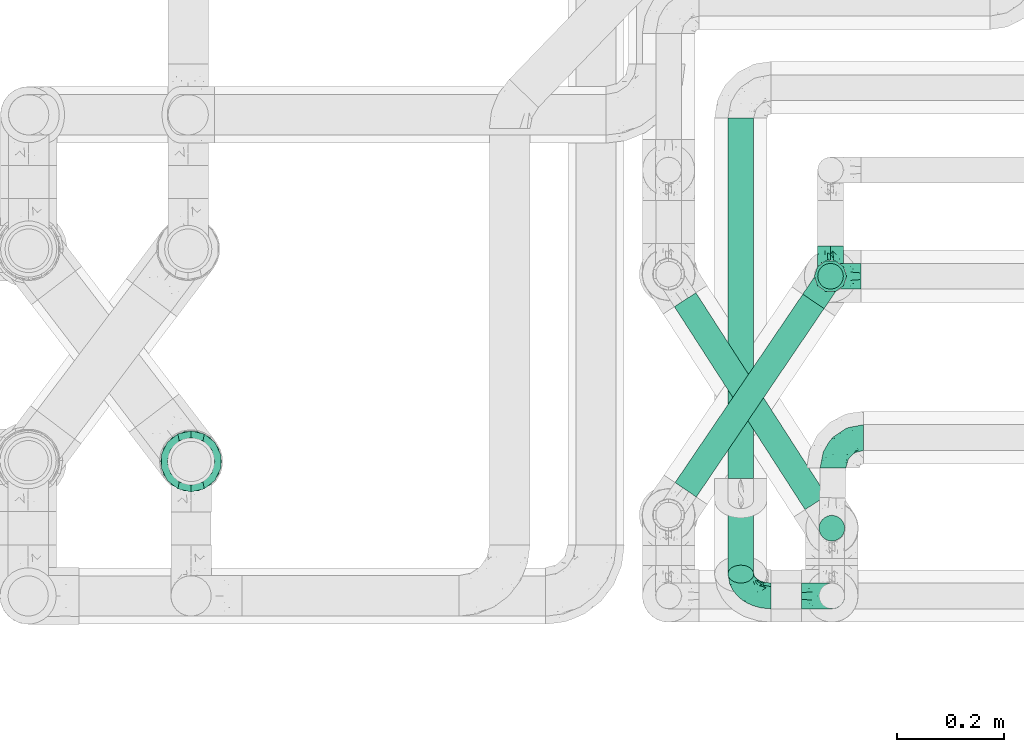
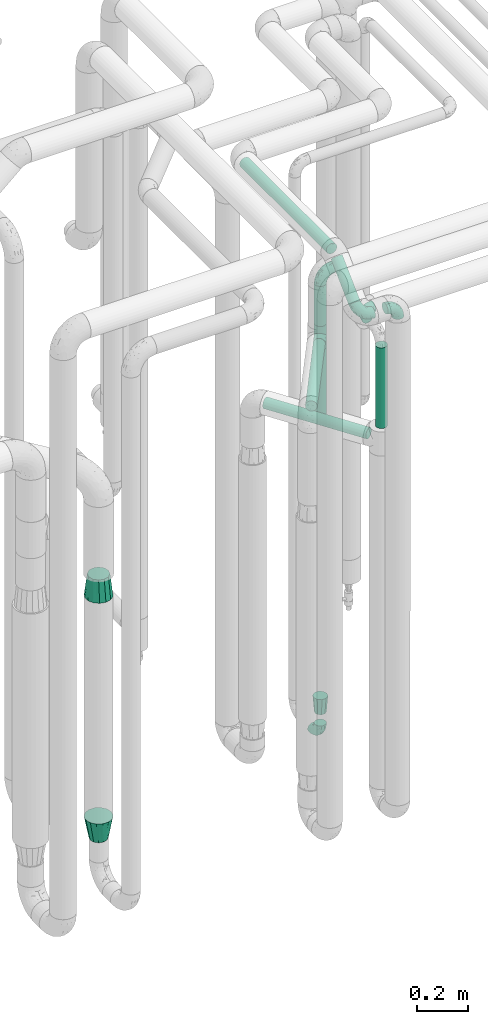
# One storey, part 662 of 827: 9 flow fittings, 7 flow segments.
"""IFC2X3 building model written with IfcOpenShell, lengths in millimetres."""

import ifcopenshell
import ifcopenshell.guid

model = None  # the IFC model being written
_history = None  # IfcOwnerHistory: only IFC2X3 demands one
_inside = {}  # id of a spatial element -> (the spatial element, [elements in it])
_under = {}  # id of a project, library or spatial element -> (it, [spatial elements below it])
_declared = {}  # id of a project -> (the project, [libraries it declares])
_typed = {}  # id of a type object -> (the type object, [elements of that type])
_made_of = {}  # id of a material, layer set ... -> (it, [elements and type objects made of it])


def new_model(schema):
    """Start an empty IFC model of exactly this schema.

    Asked for "IFC4X3", IfcOpenShell would pick the latest addendum, in which some entities
    have other attributes; the version numbers below select the first issue.
    IFC2X3 requires an IfcOwnerHistory on every rooted entity: one is made here for all.
    """
    global model, _history
    if schema == "IFC4X3":
        model = ifcopenshell.file(schema_version=(4, 3, 0, 0))
    else:
        model = ifcopenshell.file(schema=schema)
    _inside.clear()
    _under.clear()
    _declared.clear()
    _typed.clear()
    _made_of.clear()
    _history = None
    if model.schema == "IFC2X3":
        org = make("IfcOrganization", Name="unknown")
        user = make(
            "IfcPersonAndOrganization",
            ThePerson=make("IfcPerson", FamilyName="unknown"),
            TheOrganization=org,
        )
        app = make(
            "IfcApplication",
            ApplicationDeveloper=org,
            Version="unknown",
            ApplicationFullName="unknown",
            ApplicationIdentifier="unknown",
        )
        _history = make(
            "IfcOwnerHistory",
            OwningUser=user,
            OwningApplication=app,
            ChangeAction="ADDED",
            CreationDate=0,
        )
    return model


def make(cls, **values):
    """One entity of the class cls with the attributes given. An attribute that is None is left unset."""
    return model.create_entity(
        cls, **{name: value for name, value in values.items() if value is not None}
    )


def entity(cls, *values):
    """Any entity or typed value of the class cls, its attributes in the order of the schema. None: left unset."""
    e = model.create_entity(cls)
    for i, value in enumerate(values):
        if value is not None:
            e[i] = value
    return e


def rooted(cls, **values):
    """An entity with a GlobalId (a new one), such as an element, a storey or a relation."""
    return make(cls, GlobalId=ifcopenshell.guid.new(), OwnerHistory=_history, **values)


def si_unit(unit_type, name, prefix=None):
    """IfcSIUnit, for example si_unit("LENGTHUNIT", "METRE", prefix="MILLI")."""
    return make("IfcSIUnit", UnitType=unit_type, Prefix=prefix, Name=name)


def converted_unit(unit_type, name, factor, base, dimensions=None, offset=None):
    """IfcConversionBasedUnit, such as the inch: factor (a typed value) times the base unit."""
    return make(
        "IfcConversionBasedUnit"
        if offset is None
        else "IfcConversionBasedUnitWithOffset",
        ConversionOffset=offset,
        Dimensions=None
        if dimensions is None
        else entity("IfcDimensionalExponents", *dimensions),
        UnitType=unit_type,
        Name=name,
        ConversionFactor=make(
            "IfcMeasureWithUnit", ValueComponent=factor, UnitComponent=base
        ),
    )


def derived_unit(unit_type, elements):
    """IfcDerivedUnit: a product of units, each with its exponent."""
    return make(
        "IfcDerivedUnit",
        Elements=[
            make("IfcDerivedUnitElement", Unit=unit, Exponent=power)
            for unit, power in elements
        ],
        UnitType=unit_type,
    )


def assignment(units):
    """IfcUnitAssignment: the units of a project."""
    return None if units is None else make("IfcUnitAssignment", Units=units)


def point(xyz):
    """IfcCartesianPoint."""
    return None if xyz is None else make("IfcCartesianPoint", Coordinates=xyz)


def direction(xyz):
    """IfcDirection."""
    return None if xyz is None else make("IfcDirection", DirectionRatios=xyz)


def frame(location, z_axis=None, x_axis=None):
    """IfcAxis2Placement3D, a coordinate frame: its origin and axes. An axis left out is left unset."""
    return make(
        "IfcAxis2Placement3D",
        Location=point(location),
        Axis=direction(z_axis),
        RefDirection=direction(x_axis),
    )


def frame_2d(location, x_axis=None):
    """IfcAxis2Placement2D, a coordinate frame in the plane: its origin and x axis."""
    return make(
        "IfcAxis2Placement2D", Location=point(location), RefDirection=direction(x_axis)
    )


def origin():
    """The frame at (0, 0, 0) with its axes left unset."""
    return frame((0.0, 0.0, 0.0))


def origin_2d_with_axis():
    """The frame at (0, 0) in the plane with the x axis (1, 0) written out."""
    return frame_2d((0.0, 0.0), x_axis=(1.0, 0.0))


def place(relative_to, where):
    """IfcLocalPlacement: puts the frame where relative to a parent placement (None: the world)."""
    return make(
        "IfcLocalPlacement", PlacementRelTo=relative_to, RelativePlacement=where
    )


def context(
    kind, dimensions, precision=None, world=None, true_north=None, identifier=None
):
    """IfcGeometricRepresentationContext, for example the 3D "Model" context."""
    return make(
        "IfcGeometricRepresentationContext",
        ContextIdentifier=identifier,
        ContextType=kind,
        CoordinateSpaceDimension=dimensions,
        Precision=precision,
        WorldCoordinateSystem=world,
        TrueNorth=true_north,
    )


def subcontext(parent, identifier, kind, view, scale=None):
    """IfcGeometricRepresentationSubContext, for example "Body" below "Model"."""
    return make(
        "IfcGeometricRepresentationSubContext",
        ContextIdentifier=identifier,
        ContextType=kind,
        ParentContext=parent,
        TargetScale=scale,
        TargetView=view,
    )


def project(units=None, contexts=None):
    """IfcProject with its units and contexts."""
    return rooted(
        "IfcProject",
        Name="project",
        RepresentationContexts=contexts,
        UnitsInContext=assignment(units),
    )


def spatial(cls, under=None, at=None, **own):
    """A site, building, storey or space (cls), placed at a placement, below another one or the project."""
    s = rooted(cls, ObjectPlacement=at, **own)
    if under is not None:
        _under.setdefault(under.id(), (under, []))[1].append(s)
    return s


def profile(cls, at=None, kind="AREA", **sizes):
    """A parametric profile (cls). Its sizes go by their IFC names, for example OverallWidth=200.0."""
    return make(cls, ProfileType=kind, Position=at, **sizes)


def circle(**sizes):
    """IfcCircleProfileDef."""
    return profile("IfcCircleProfileDef", **sizes)


def extrude(swept, where, along, depth):
    """IfcExtrudedAreaSolid: the profile swept, set in the frame where, extruded along a direction by depth."""
    return make(
        "IfcExtrudedAreaSolid",
        SweptArea=swept,
        Position=where,
        ExtrudedDirection=direction(along),
        Depth=depth,
    )


def faces_of(points, faces, orient=None, outer=None):
    """IfcFace entities. A face is a list of loops; a loop is a list of indices into points, from 0.

    orient and outer hold one flag for each loop. By default every Orientation is true, the
    first loop of a face is its IfcFaceOuterBound and the others are IfcFaceBound.
    """
    made = []
    for i, loops in enumerate(faces):
        bounds = []
        for j, loop in enumerate(loops):
            is_outer = j == 0 if outer is None else outer[i][j]
            bounds.append(
                make(
                    "IfcFaceOuterBound" if is_outer else "IfcFaceBound",
                    Bound=make("IfcPolyLoop", Polygon=[points[k] for k in loop]),
                    Orientation=True if orient is None else orient[i][j],
                )
            )
        made.append(make("IfcFace", Bounds=bounds))
    return made


def faceted_brep(points, faces, orient=None, outer=None, voids=None):
    """IfcFacetedBrep: a solid bounded by flat faces; with voids (closed shells), ...WithVoids."""
    shared = [point(p) for p in points]
    hull = make("IfcClosedShell", CfsFaces=faces_of(shared, faces, orient, outer))
    if voids is None:
        return make("IfcFacetedBrep", Outer=hull)
    return make(
        "IfcFacetedBrepWithVoids",
        Outer=hull,
        Voids=[
            make(cls, CfsFaces=faces_of(shared, fs, o, b)) for cls, fs, o, b in voids
        ],
    )


def shape(context_of_items, identifier, shape_type, items):
    """IfcShapeRepresentation: the items that make up one representation, for example the "Body"."""
    return make(
        "IfcShapeRepresentation",
        ContextOfItems=context_of_items,
        RepresentationIdentifier=identifier,
        RepresentationType=shape_type,
        Items=items,
    )


def source(mapping_origin, context_of_items, identifier, shape_type, items):
    """IfcRepresentationMap: a shape defined once, which mapped items show again and again."""
    return make(
        "IfcRepresentationMap",
        MappingOrigin=mapping_origin,
        MappedRepresentation=shape(context_of_items, identifier, shape_type, items),
    )


def transform(
    local_origin,
    x_axis=None,
    y_axis=None,
    z_axis=None,
    scale=None,
    scale2=None,
    scale3=None,
    uniform=True,
):
    """IfcCartesianTransformationOperator3D, or its non-uniform kind. x_axis, y_axis, z_axis: its Axis1, 2, 3."""
    if uniform:
        return make(
            "IfcCartesianTransformationOperator3D",
            Axis1=direction(x_axis),
            Axis2=direction(y_axis),
            LocalOrigin=point(local_origin),
            Scale=scale,
            Axis3=direction(z_axis),
        )
    return make(
        "IfcCartesianTransformationOperator3DnonUniform",
        Axis1=direction(x_axis),
        Axis2=direction(y_axis),
        LocalOrigin=point(local_origin),
        Scale=scale,
        Axis3=direction(z_axis),
        Scale2=scale2,
        Scale3=scale3,
    )


def mapped(mapping_source, mapping_target):
    """IfcMappedItem: shows the shape of a source again, moved by a transform."""
    return make(
        "IfcMappedItem", MappingSource=mapping_source, MappingTarget=mapping_target
    )


def material(Name=None, Category=None):
    """IfcMaterial."""
    return make("IfcMaterial", Name=Name, Category=Category)


def made_of(thing, what):
    """Note that an element or type object is made of a material, layer set ...; save() writes the relation."""
    if what is not None:
        _made_of.setdefault(what.id(), (what, []))[1].append(thing)
    return thing


def type_object(cls, material=None, **own):
    """A type object (cls), such as IfcWallType, which elements share."""
    return made_of(rooted(cls, **own), material)


def type_shapes(of_type, sources):
    """Give a type object the sources (RepresentationMaps) that its elements show as mapped items."""
    of_type.RepresentationMaps = sources


def element(
    cls,
    number,
    at=None,
    inside=None,
    cuts=None,
    type_object=None,
    material=None,
    context=None,
    identifier="Body",
    shape_type=None,
    held_by="IfcProductDefinitionShape",
    body=None,
    shapes=None,
    **own,
):
    """One element of the class cls, such as IfcWall. Its Tag is "e" and its number.

    at: its placement. inside: the storey or other place that contains it. cuts: it is an
    opening in that element (IfcRelVoidsElement). A single representation is given by context,
    identifier, shape_type and body (its items); several are given by shapes. held_by: the class
    of the entity that holds the representations. save() writes the other relations.
    """
    e = rooted(cls, Tag="e%d" % number, ObjectPlacement=at, **own)
    if body is not None:
        shapes = [shape(context, identifier, shape_type, body)]
    if shapes is not None:
        e.Representation = make(held_by, Representations=shapes)
    if inside is not None:
        _inside.setdefault(inside.id(), (inside, []))[1].append(e)
    if cuts is not None:
        rooted(
            "IfcRelVoidsElement", RelatingBuildingElement=cuts, RelatedOpeningElement=e
        )
    if type_object is not None:
        _typed.setdefault(type_object.id(), (type_object, []))[1].append(e)
    return made_of(e, material)


def aggregate(whole, parts):
    """IfcRelAggregates: a whole, such as a stair, and the parts it consists of."""
    return rooted("IfcRelAggregates", RelatingObject=whole, RelatedObjects=parts)


def save(model, path):
    """Write the relations noted so far, then the file.

    IfcRelAggregates (storeys below a building ...), IfcRelContainedInSpatialStructure (elements
    in a storey), IfcRelDefinesByType, IfcRelAssociatesMaterial and IfcRelDeclares: one each for
    every whole, place, type object, material and project.
    """
    for whole, parts in _under.values():
        aggregate(whole, parts)
    for where, things in _inside.values():
        rooted(
            "IfcRelContainedInSpatialStructure",
            RelatedElements=things,
            RelatingStructure=where,
        )
    for kind, things in _typed.values():
        rooted("IfcRelDefinesByType", RelatedObjects=things, RelatingType=kind)
    for what, things in _made_of.values():
        rooted("IfcRelAssociatesMaterial", RelatedObjects=things, RelatingMaterial=what)
    for by, libraries in _declared.values():
        rooted("IfcRelDeclares", RelatingContext=by, RelatedDefinitions=libraries)
    model.write(path)


model = new_model("IFC2X3")

# Units and contexts
model_context = context("Model", 3, precision=0.01, world=origin(), true_north=direction((6.12303176911189e-17, 1.0)))
body_context = subcontext(model_context, "Body", "Model", "MODEL_VIEW")
ifc_project = project(units=[si_unit("LENGTHUNIT", "METRE", prefix="MILLI"), si_unit("AREAUNIT", "SQUARE_METRE"), si_unit("VOLUMEUNIT", "CUBIC_METRE"), converted_unit("PLANEANGLEUNIT", "DEGREE", entity("IfcRatioMeasure", 0.0174532925199433), si_unit("PLANEANGLEUNIT", "RADIAN"), dimensions=[0, 0, 0, 0, 0, 0, 0]), si_unit("MASSUNIT", "GRAM", prefix="KILO"), derived_unit("MASSDENSITYUNIT", [(si_unit("MASSUNIT", "GRAM", prefix="KILO"), 1), (si_unit("LENGTHUNIT", "METRE"), -3)]), derived_unit("MOMENTOFINERTIAUNIT", [(si_unit("LENGTHUNIT", "METRE"), 4)]), si_unit("TIMEUNIT", "SECOND"), si_unit("FREQUENCYUNIT", "HERTZ"), si_unit("THERMODYNAMICTEMPERATUREUNIT", "DEGREE_CELSIUS"), derived_unit("THERMALTRANSMITTANCEUNIT", [(si_unit("MASSUNIT", "GRAM", prefix="KILO"), 1), (si_unit("THERMODYNAMICTEMPERATUREUNIT", "KELVIN"), -1), (si_unit("TIMEUNIT", "SECOND"), -3)]), derived_unit("VOLUMETRICFLOWRATEUNIT", [(si_unit("LENGTHUNIT", "METRE"), 3), (si_unit("TIMEUNIT", "SECOND"), -1)]), derived_unit("MASSFLOWRATEUNIT", [(si_unit("MASSUNIT", "GRAM", prefix="KILO"), 1), (si_unit("TIMEUNIT", "SECOND"), -1)]), derived_unit("ROTATIONALFREQUENCYUNIT", [(si_unit("TIMEUNIT", "SECOND"), -1)]), si_unit("ELECTRICCURRENTUNIT", "AMPERE"), si_unit("ELECTRICVOLTAGEUNIT", "VOLT"), si_unit("POWERUNIT", "WATT"), si_unit("FORCEUNIT", "NEWTON", prefix="KILO"), si_unit("ILLUMINANCEUNIT", "LUX"), si_unit("LUMINOUSFLUXUNIT", "LUMEN"), si_unit("LUMINOUSINTENSITYUNIT", "CANDELA"), derived_unit("USERDEFINED", [(si_unit("MASSUNIT", "GRAM", prefix="KILO"), -1), (si_unit("LENGTHUNIT", "METRE"), -2), (si_unit("TIMEUNIT", "SECOND"), 3), (si_unit("LUMINOUSFLUXUNIT", "LUMEN"), 1)]), derived_unit("LINEARVELOCITYUNIT", [(si_unit("LENGTHUNIT", "METRE"), 1), (si_unit("TIMEUNIT", "SECOND"), -1)]), si_unit("PRESSUREUNIT", "PASCAL"), derived_unit("USERDEFINED", [(si_unit("LENGTHUNIT", "METRE"), -2), (si_unit("MASSUNIT", "GRAM", prefix="KILO"), 1), (si_unit("TIMEUNIT", "SECOND"), -2)]), derived_unit("LINEARFORCEUNIT", [(si_unit("MASSUNIT", "GRAM", prefix="KILO"), 1), (si_unit("LENGTHUNIT", "METRE"), 1), (si_unit("TIMEUNIT", "SECOND"), -2), (si_unit("LENGTHUNIT", "METRE"), -1)]), derived_unit("PLANARFORCEUNIT", [(si_unit("MASSUNIT", "GRAM", prefix="KILO"), 1), (si_unit("LENGTHUNIT", "METRE"), 1), (si_unit("TIMEUNIT", "SECOND"), -2), (si_unit("LENGTHUNIT", "METRE"), -2)])], contexts=[model_context])

# Site, building, storey
site_placement = place(None, origin())
site = spatial("IfcSite", under=ifc_project, at=site_placement, CompositionType="ELEMENT")
building_placement = place(site_placement, origin())
building = spatial("IfcBuilding", under=site, at=building_placement, CompositionType="ELEMENT")
storey_placement = place(building_placement, frame((0.0, 0.0, 28200.0)))
storey = spatial("IfcBuildingStorey", under=building, at=storey_placement, Name="08", CompositionType="ELEMENT", Elevation=28200.0)

# Flow segments
pipe_segment_type = type_object("IfcPipeSegmentType", PredefinedType="NOTDEFINED")
flow_segment_1_placement = place(storey_placement, frame((46970.44, 14210.08, 1925.0)))
element("IfcFlowSegment", 1, at=flow_segment_1_placement, inside=storey, type_object=pipe_segment_type, context=body_context, shape_type="SweptSolid", body=[
    extrude(circle(Radius=24.0, at=origin_2d_with_axis()), frame((25.6, 25.6, 0.0)), (0.0, 0.0, 1.0), 318.000000000019),
])
flow_segment_2_placement = place(storey_placement, frame((46802.4, 13856.65, 2974.4)))
element("IfcFlowSegment", 2, at=flow_segment_2_placement, inside=storey, type_object=pipe_segment_type, context=body_context, shape_type="SweptSolid", body=[
    extrude(circle(Radius=24.0, at=origin_2d_with_axis()), frame((25.6, 0.0, 25.6), z_axis=(0.0, 1.0, 0.0), x_axis=(-1.0, 0.0, 0.0)), (0.0, 0.0, 1.0), 675.09993070178),
])
flow_segment_3_placement = place(storey_placement, frame((46802.4, 13659.54, 2830.55)))
element("IfcFlowSegment", 3, at=flow_segment_3_placement, inside=storey, type_object=pipe_segment_type, context=body_context, shape_type="SweptSolid", body=[
    extrude(circle(Radius=24.0, at=origin_2d_with_axis()), frame((25.6, 18.28, 18.85), z_axis=(0.0, 0.718969901615606, 0.695041207822131), x_axis=(1.0, 0.0, 0.0)), (0.0, 0.0, 1.0), 193.624123419375),
])
flow_segment_4_placement = place(storey_placement, frame((46702.01, 13796.99, 2074.52)))
element("IfcFlowSegment", 4, at=flow_segment_4_placement, inside=storey, type_object=pipe_segment_type, context=body_context, shape_type="SweptSolid", body=[
    extrude(circle(Radius=24.0, at=origin_2d_with_axis()), frame((266.58, 14.59, 25.6), z_axis=(-0.541458405671931, 0.840727539056032, 0.0), x_axis=(-0.840727539056032, -0.541458405671931, 0.0)), (0.0, 0.0, 1.0), 452.120905442338),
])
flow_segment_5_placement = place(storey_placement, frame((46703.32, 13820.62, 2274.4)))
element("IfcFlowSegment", 5, at=flow_segment_5_placement, inside=storey, type_object=pipe_segment_type, context=body_context, shape_type="SweptSolid", body=[
    extrude(circle(Radius=24.0, at=origin_2d_with_axis()), frame((21.46, 15.07, 25.6), z_axis=(0.561257826257731, 0.827641016663896, 0.0), x_axis=(0.827641016663896, -0.561257826257731, 0.0)), (0.0, 0.0, 1.0), 426.29652281039),
])
flow_segment_6_placement = place(storey_placement, frame((46970.44, 14210.08, 2357.0)))
element("IfcFlowSegment", 6, at=flow_segment_6_placement, inside=storey, type_object=pipe_segment_type, context=body_context, shape_type="SweptSolid", body=[
    extrude(circle(Radius=24.0, at=origin_2d_with_axis()), frame((25.6, 25.6, 0.0)), (0.0, 0.0, 1.0), 191.0),
])
flow_segment_7_placement = place(storey_placement, frame((46972.93, 13738.17, 2157.11)))
element("IfcFlowSegment", 7, at=flow_segment_7_placement, inside=storey, type_object=pipe_segment_type, context=body_context, shape_type="SweptSolid", body=[
    extrude(circle(Radius=24.0, at=origin_2d_with_axis()), frame((25.6, 25.6, 0.0), z_axis=(0.0, 0.0, 1.0), x_axis=(-1.0, 0.0, 0.0)), (0.0, 0.0, 1.0), 383.342450477676),
])

# Flow fittings
ifc_material = material()
pipe_fitting_type_1 = type_object("IfcPipeFittingType", Name="ADSK_1", PredefinedType="NOTDEFINED", material=ifc_material)
shared_shape_1 = source(origin(), body_context, "Body", "Brep", [
    faceted_brep([(-57.0, 12.07, -20.91), (-57.0, 6.25, -23.33), (-57.0, 0.0, -24.15), (-57.0, -6.25, -23.33), (-57.0, -12.08, -20.91), (-57.0, -17.08, -17.08), (-57.0, -20.91, -12.08), (-57.0, -23.33, -6.25), (-57.0, -24.15, 0.0), (-57.0, -23.33, 6.25), (-57.0, -20.91, 12.07), (-57.0, -17.08, 17.08), (-57.0, -12.08, 20.91), (-57.0, -6.25, 23.33), (-57.0, 0.0, 24.15), (-57.0, 6.25, 23.33), (-57.0, 12.07, 20.91), (-57.0, 17.08, 17.08), (-57.0, 20.91, 12.07), (-57.0, 23.33, 6.25), (-57.0, 24.15, 0.0), (-57.0, 23.33, -6.25), (-57.0, 20.91, -12.08), (-57.0, 17.08, -17.08), (0.0, 57.0, -24.15), (-6.25, 57.0, -23.33), (-12.07, 57.0, -20.91), (-17.08, 57.0, -17.08), (-20.91, 57.0, -12.08), (-23.33, 57.0, -6.25), (-24.15, 57.0, 0.0), (-23.33, 57.0, 6.25), (-20.91, 57.0, 12.07), (-17.08, 57.0, 17.08), (-12.07, 57.0, 20.91), (-6.25, 57.0, 23.33), (0.0, 57.0, 24.15), (6.25, 57.0, 23.33), (12.08, 57.0, 20.91), (17.08, 57.0, 17.08), (20.91, 57.0, 12.07), (23.33, 57.0, 6.25), (24.15, 57.0, 0.0), (23.33, 57.0, -6.25), (20.91, 57.0, -12.08), (17.08, 57.0, -17.08), (12.08, 57.0, -20.91), (6.25, 57.0, -23.33), (14.9, 21.14, 6.17), (13.61, 24.64, 12.48), (6.23, 8.95, 8.98), (-41.47, -21.06, 0.0), (-41.92, -18.38, 13.72), (-24.64, -13.61, 12.48), (-37.37, -13.24, 18.15), (-6.8, -4.93, 8.18), (-21.76, -15.19, 6.22), (-12.78, -9.18, 0.0), (-37.73, -20.51, 7.75), (-7.38, 7.38, 20.24), (-23.37, -4.26, 20.42), (-11.9, -3.19, 15.86), (-42.14, -8.7, 21.82), (13.24, 37.37, 18.15), (9.33, 23.53, 16.85), (4.26, 23.37, 20.42), (2.77, 10.92, 15.55), (-29.46, 0.91, 23.52), (-44.13, 20.56, 15.69), (-39.25, 26.33, 10.88), (-49.02, 22.92, 9.96), (-34.58, 23.87, 17.15), (-15.8, 6.8, 22.81), (-8.67, 20.47, 23.88), (-18.12, 12.9, 24.08), (-48.29, 14.92, 19.65), (-44.06, -2.85, 23.78), (-9.23, 48.95, 22.58), (-3.78, 42.74, 24.07), (-40.34, 4.26, 24.09), (-44.02, 26.14, 5.46), (-44.04, 9.88, 22.74), (-4.95, 16.87, 22.52), (-2.75, 1.43, 12.5), (-25.48, 40.98, 10.71), (20.51, 37.73, 7.75), (18.38, 41.92, 13.72), (8.7, 42.14, 21.82), (-25.95, -17.97, 0.0), (2.85, 44.06, 23.78), (21.06, 41.47, 0.0), (17.97, 25.95, 0.0), (-24.04, -9.27, 17.13), (-33.26, 33.26, 5.86), (-28.55, 40.57, 0.0), (-40.57, 28.55, 0.0), (-25.29, 47.19, 4.06), (-27.01, 31.1, 16.77), (-15.7, 43.95, 19.9), (-20.27, 45.22, 15.61), (-30.53, 31.98, 12.64), (-11.28, 38.33, 22.92), (-9.97, 27.88, 24.09), (-20.15, 30.26, 21.25), (-31.25, 11.75, 23.64), (-28.75, 7.23, 24.15), (-29.53, 18.06, 22.27), (-28.44, 24.21, 20.02), (-37.55, 17.7, 20.26), (-15.88, 29.25, 22.99), (-20.82, 20.82, 23.44), (-0.91, 29.46, 23.52), (-13.5, -7.67, 12.04), (1.49, 1.56, 5.16), (8.86, 10.35, 4.59), (0.38, -0.38, 0.0), (9.18, 12.78, 0.0), (-37.37, -13.24, -18.15), (8.86, 10.35, -4.59), (-45.22, 20.27, -15.61), (-43.95, 15.7, -19.9), (-38.33, 11.28, -22.92), (-48.95, 9.23, -22.58), (-47.19, 25.29, -4.06), (-33.26, 33.26, -5.86), (18.38, 41.92, -13.72), (-30.26, 20.15, -21.25), (2.85, 44.06, -23.78), (-4.26, 40.34, -24.09), (-40.98, 25.48, -10.71), (-41.92, -18.38, -13.72), (9.25, 23.5, -16.92), (4.26, 23.37, -20.42), (13.24, 37.37, -18.15), (-37.73, -20.51, -7.75), (-11.75, 31.25, -23.64), (-7.23, 28.75, -24.15), (-12.9, 18.12, -24.08), (8.7, 42.14, -21.82), (-44.06, -2.85, -23.78), (-6.8, 15.8, -22.81), (-20.47, 8.67, -23.88), (-24.64, -13.61, -12.48), (-42.74, 3.78, -24.07), (-18.06, 29.53, -22.27), (-24.21, 28.44, -20.02), (-27.88, 9.97, -24.09), (-31.1, 27.01, -16.77), (-26.14, 44.02, -5.46), (14.9, 21.14, -6.17), (20.51, 37.73, -7.75), (-9.88, 44.04, -22.74), (-20.56, 44.13, -15.69), (-21.76, -15.19, -6.22), (-13.5, -7.67, -12.04), (-24.14, -9.76, -16.74), (-11.9, -3.19, -15.86), (-14.92, 48.29, -19.65), (-23.37, -4.26, -20.42), (-0.91, 29.46, -23.52), (-26.33, 39.25, -10.88), (-23.87, 34.58, -17.15), (-42.14, -8.7, -21.82), (-22.92, 49.02, -9.96), (13.61, 24.64, -12.48), (-31.98, 30.53, -12.64), (-16.87, 4.95, -22.52), (-17.7, 37.55, -20.26), (-29.25, 15.88, -22.99), (-20.82, 20.82, -23.44), (-29.46, 0.91, -23.52), (-7.38, 7.38, -20.24), (2.77, 10.92, -15.55), (6.23, 8.95, -8.98), (-6.8, -4.93, -8.18), (-2.81, 1.41, -12.54), (1.49, 1.56, -5.16)], [[[0, 1, 2, 3, 4, 5, 6, 7, 8, 9, 10, 11, 12, 13, 14, 15, 16, 17, 18, 19, 20, 21, 22, 23]], [[24, 25, 26, 27, 28, 29, 30, 31, 32, 33, 34, 35, 36, 37, 38, 39, 40, 41, 42, 43, 44, 45, 46, 47]], [[48, 49, 50]], [[9, 8, 51]], [[52, 53, 54]], [[55, 56, 57]], [[10, 58, 52]], [[9, 58, 10]], [[59, 60, 61]], [[54, 12, 11]], [[54, 62, 12]], [[63, 39, 38]], [[64, 65, 66]], [[62, 60, 67]], [[68, 69, 70]], [[71, 69, 68]], [[72, 73, 74]], [[16, 75, 17]], [[13, 76, 14]], [[35, 77, 78]], [[14, 79, 15]], [[17, 68, 18]], [[14, 76, 79]], [[20, 19, 80]], [[70, 19, 18]], [[81, 15, 79]], [[15, 81, 16]], [[73, 72, 82]], [[66, 83, 50]], [[32, 31, 84]], [[85, 86, 49]], [[63, 87, 65]], [[56, 58, 88]], [[36, 89, 37]], [[85, 41, 40]], [[36, 35, 78]], [[90, 41, 85]], [[40, 39, 86]], [[12, 62, 13]], [[86, 85, 40]], [[48, 85, 49]], [[85, 91, 90]], [[87, 38, 37]], [[92, 60, 54]], [[80, 69, 93]], [[93, 94, 95]], [[10, 52, 11]], [[94, 96, 30]], [[97, 98, 99]], [[80, 93, 95]], [[100, 97, 84]], [[99, 98, 33]], [[101, 102, 78]], [[103, 101, 98]], [[96, 31, 30]], [[77, 98, 101]], [[77, 35, 34]], [[34, 33, 98]], [[9, 51, 58]], [[87, 63, 38]], [[104, 105, 74]], [[106, 103, 107]], [[106, 81, 104]], [[75, 68, 17]], [[108, 107, 71]], [[33, 32, 99]], [[109, 103, 110]], [[101, 109, 102]], [[89, 78, 111]], [[53, 52, 58]], [[54, 11, 52]], [[60, 62, 54]], [[88, 58, 51]], [[76, 62, 67]], [[53, 112, 92]], [[60, 59, 72]], [[39, 63, 86]], [[49, 86, 63]], [[89, 87, 37]], [[42, 41, 90]], [[111, 82, 65]], [[111, 65, 87]], [[65, 59, 66]], [[104, 81, 79]], [[75, 81, 108]], [[32, 84, 99]], [[97, 99, 84]], [[98, 97, 103]], [[106, 107, 108]], [[74, 102, 110]], [[111, 78, 102]], [[74, 110, 104]], [[74, 67, 72]], [[61, 92, 112]], [[66, 59, 61]], [[56, 53, 58]], [[66, 50, 49]], [[61, 112, 83]], [[66, 49, 64]], [[78, 89, 36]], [[87, 89, 111]], [[62, 76, 13]], [[79, 76, 67]], [[100, 93, 69]], [[96, 93, 84]], [[55, 113, 50]], [[113, 114, 50]], [[104, 79, 105]], [[106, 104, 110]], [[20, 80, 95]], [[85, 48, 91]], [[115, 114, 113]], [[116, 91, 48]], [[70, 80, 19]], [[93, 96, 94]], [[84, 31, 96]], [[103, 106, 110]], [[81, 106, 108]], [[103, 97, 107]], [[71, 107, 97]], [[71, 97, 100]], [[108, 71, 68]], [[79, 67, 105]], [[67, 74, 105]], [[115, 113, 57]], [[112, 56, 55]], [[56, 88, 57]], [[60, 72, 67]], [[82, 72, 59]], [[65, 82, 59]], [[82, 111, 73]], [[111, 102, 73]], [[102, 74, 73]], [[81, 75, 16]], [[68, 75, 108]], [[68, 70, 18]], [[80, 70, 69]], [[98, 77, 34]], [[78, 77, 101]], [[93, 100, 84]], [[71, 100, 69]], [[102, 109, 110]], [[101, 103, 109]], [[53, 92, 54]], [[61, 60, 92]], [[56, 112, 53]], [[83, 112, 55]], [[50, 83, 55]], [[61, 83, 66]], [[49, 63, 64]], [[65, 64, 63]], [[57, 113, 55]], [[114, 115, 116]], [[116, 48, 114]], [[48, 50, 114]], [[117, 5, 4]], [[116, 115, 118]], [[119, 120, 23]], [[121, 122, 120]], [[95, 123, 20]], [[0, 23, 120]], [[124, 95, 94]], [[125, 45, 44]], [[121, 120, 126]], [[24, 127, 128]], [[22, 21, 129]], [[0, 122, 1]], [[5, 117, 130]], [[131, 132, 133]], [[134, 88, 51]], [[135, 136, 137]], [[6, 5, 130]], [[46, 138, 47]], [[139, 3, 2]], [[140, 141, 137]], [[6, 134, 7]], [[134, 130, 142]], [[143, 2, 1]], [[144, 126, 145]], [[121, 146, 143]], [[147, 120, 119]], [[94, 148, 124]], [[149, 150, 91]], [[30, 29, 148]], [[151, 25, 128]], [[27, 152, 28]], [[134, 153, 88]], [[154, 155, 156]], [[27, 26, 157]], [[151, 26, 25]], [[155, 158, 156]], [[24, 47, 127]], [[1, 122, 143]], [[138, 132, 159]], [[160, 152, 161]], [[24, 128, 25]], [[46, 133, 138]], [[162, 117, 4]], [[148, 160, 124]], [[152, 160, 163]], [[154, 142, 155]], [[45, 125, 133]], [[133, 46, 45]], [[125, 164, 133]], [[51, 7, 134]], [[42, 90, 43]], [[165, 147, 129]], [[153, 134, 142]], [[43, 150, 44]], [[162, 4, 3]], [[141, 140, 166]], [[117, 162, 158]], [[163, 29, 28]], [[43, 90, 150]], [[123, 21, 20]], [[144, 151, 135]], [[157, 152, 27]], [[167, 145, 161]], [[23, 22, 119]], [[168, 126, 169]], [[121, 168, 146]], [[139, 143, 170]], [[142, 130, 117]], [[8, 7, 51]], [[134, 6, 130]], [[139, 162, 3]], [[170, 166, 158]], [[170, 158, 162]], [[158, 171, 156]], [[44, 150, 125]], [[91, 150, 90]], [[164, 125, 150]], [[132, 138, 133]], [[127, 138, 159]], [[131, 164, 172]], [[132, 171, 140]], [[135, 151, 128]], [[157, 151, 167]], [[22, 129, 119]], [[147, 119, 129]], [[120, 147, 126]], [[144, 145, 167]], [[137, 146, 169]], [[170, 143, 146]], [[137, 169, 135]], [[137, 159, 140]], [[171, 172, 156]], [[173, 174, 175]], [[156, 175, 154]], [[174, 57, 153]], [[132, 172, 171]], [[172, 164, 173]], [[143, 139, 2]], [[162, 139, 170]], [[138, 127, 47]], [[128, 127, 159]], [[165, 124, 160]], [[123, 124, 129]], [[149, 173, 164]], [[176, 174, 173]], [[135, 128, 136]], [[144, 135, 169]], [[150, 149, 164]], [[176, 118, 115]], [[149, 91, 116]], [[30, 148, 94]], [[163, 148, 29]], [[124, 123, 95]], [[129, 21, 123]], [[126, 144, 169]], [[151, 144, 167]], [[126, 147, 145]], [[161, 145, 147]], [[161, 147, 165]], [[167, 161, 152]], [[128, 159, 136]], [[159, 137, 136]], [[154, 153, 142]], [[132, 140, 159]], [[174, 176, 57]], [[57, 88, 153]], [[166, 140, 171]], [[158, 166, 171]], [[166, 170, 141]], [[170, 146, 141]], [[146, 137, 141]], [[151, 157, 26]], [[152, 157, 167]], [[152, 163, 28]], [[148, 163, 160]], [[120, 122, 0]], [[143, 122, 121]], [[124, 165, 129]], [[161, 165, 160]], [[146, 168, 169]], [[121, 126, 168]], [[142, 117, 155]], [[158, 155, 117]], [[175, 156, 172]], [[153, 154, 174]], [[173, 175, 172]], [[174, 154, 175]], [[164, 131, 133]], [[172, 132, 131]], [[176, 173, 118]], [[57, 176, 115]], [[173, 149, 118]], [[149, 116, 118]]]),
])
type_shapes(pipe_fitting_type_1, [shared_shape_1])
for number, where, z_axis, x_axis, name in (
    (8, (47000.67, 13933.51, 2597.45), (0.0, 0.0, 1.0), (-1.0, 0.0, 0.0), "ADSK_1"),
    (9, (46996.03, 14235.68, 400.0), (-1.0, 0.0, 0.0), (0.0, -1.0, 0.0), "ADSK_1"),
    (10, (46828.0, 13636.84, 2809.79), (0.0, 0.695041207822159, -0.718969901615578), (-1.0, 0.0, 0.0), "ADSK_1"),
    (11, (46998.53, 13636.84, 2809.79), (0.0, 0.999999986750721, 0.000162783775418001), (1.0, 0.0, 2.64985632374224e-08), "ADSK_1"),
    (12, (46996.03, 14235.68, 2605.0), (0.0, -1.0, 0.0), (-1.0, 0.0, 0.0), "ADSK_1"),
):
    element("IfcFlowFitting", number, at=place(storey_placement, frame(where, z_axis=z_axis, x_axis=x_axis)), inside=storey, type_object=pipe_fitting_type_1, material=ifc_material, Name=name, ObjectType="ADSK_1", context=body_context, shape_type="MappedRepresentation", body=[
        mapped(shared_shape_1, transform((0.0, 0.0, 0.0), scale=1.0)),
    ])
pipe_fitting_type_2 = type_object("IfcPipeFittingType", Name="ADSK_1", PredefinedType="NOTDEFINED", material=ifc_material)
shared_shape_2 = source(origin(), body_context, "Body", "Brep", [
    faceted_brep([(-57.0, 12.07, -20.91), (-57.0, 6.25, -23.33), (-57.0, 0.0, -24.15), (-57.0, -6.25, -23.33), (-57.0, -12.08, -20.91), (-57.0, -17.08, -17.08), (-57.0, -20.91, -12.08), (-57.0, -23.33, -6.25), (-57.0, -24.15, 0.0), (-57.0, -23.33, 6.25), (-57.0, -20.91, 12.07), (-57.0, -17.08, 17.08), (-57.0, -12.08, 20.91), (-57.0, -6.25, 23.33), (-57.0, 0.0, 24.15), (-57.0, 6.25, 23.33), (-57.0, 12.07, 20.91), (-57.0, 17.08, 17.08), (-57.0, 20.91, 12.07), (-57.0, 23.33, 6.25), (-57.0, 24.15, 0.0), (-57.0, 23.33, -6.25), (-57.0, 20.91, -12.08), (-57.0, 17.08, -17.08), (57.0, 0.0, -24.15), (57.0, 6.25, -23.33), (57.0, 12.07, -20.91), (57.0, 17.08, -17.08), (57.0, 20.91, -12.08), (57.0, 23.33, -6.25), (57.0, 24.15, 0.0), (57.0, 23.33, 6.25), (57.0, 20.91, 12.07), (57.0, 17.08, 17.08), (57.0, 12.07, 20.91), (57.0, 6.25, 23.33), (57.0, 0.0, 24.15), (57.0, -6.25, 23.33), (57.0, -12.08, 20.91), (57.0, -17.08, 17.08), (57.0, -20.91, 12.07), (57.0, -23.33, 6.25), (57.0, -24.15, 0.0), (57.0, -23.33, -6.25), (57.0, -20.91, -12.08), (57.0, -17.08, -17.08), (57.0, -12.08, -20.91), (57.0, -6.25, -23.33), (23.27, -23.27, 6.45), (24.15, -24.15, 0.0), (-24.15, -24.15, 0.0), (20.9, -20.9, 12.1), (13.54, -13.54, 20.0), (17.52, -17.52, 16.62), (-23.27, -23.27, 6.45), (-20.9, -20.9, 12.1), (-17.52, -17.52, 16.62), (-13.54, -13.54, 20.0), (-9.19, -9.19, 22.33), (9.19, -9.19, 22.33), (4.64, -4.64, 23.7), (0.0, 0.0, 24.15), (-4.64, -4.64, 23.7), (4.64, -4.64, -23.7), (0.0, 0.0, -24.15), (-4.64, -4.64, -23.7), (-9.19, -9.19, -22.33), (9.19, -9.19, -22.33), (13.54, -13.54, -20.0), (17.52, -17.52, -16.62), (20.9, -20.9, -12.1), (23.27, -23.27, -6.45), (-13.54, -13.54, -20.0), (-17.52, -17.52, -16.62), (-23.27, -23.27, -6.45), (-20.9, -20.9, -12.1), (0.0, -57.0, -24.15), (6.25, -57.0, -23.33), (12.08, -57.0, -20.91), (17.08, -57.0, -17.08), (20.91, -57.0, -12.08), (23.33, -57.0, -6.25), (24.15, -57.0, 0.0), (23.33, -57.0, 6.25), (20.91, -57.0, 12.07), (17.08, -57.0, 17.08), (12.08, -57.0, 20.91), (6.25, -57.0, 23.33), (0.0, -57.0, 24.15), (-6.25, -57.0, 23.33), (-12.07, -57.0, 20.91), (-17.08, -57.0, 17.08), (-20.91, -57.0, 12.07), (-23.33, -57.0, 6.25), (-24.15, -57.0, 0.0), (-23.33, -57.0, -6.25), (-20.91, -57.0, -12.08), (-17.08, -57.0, -17.08), (-12.07, -57.0, -20.91), (-6.25, -57.0, -23.33)], [[[0, 1, 2, 3, 4, 5, 6, 7, 8, 9, 10, 11, 12, 13, 14, 15, 16, 17, 18, 19, 20, 21, 22, 23]], [[24, 25, 26, 27, 28, 29, 30, 31, 32, 33, 34, 35, 36, 37, 38, 39, 40, 41, 42, 43, 44, 45, 46, 47]], [[41, 40, 48]], [[42, 41, 49]], [[50, 9, 8]], [[49, 41, 48]], [[40, 51, 48]], [[39, 38, 52]], [[51, 40, 53]], [[52, 53, 39]], [[53, 40, 39]], [[50, 54, 9]], [[9, 54, 10]], [[54, 55, 10]], [[56, 57, 11]], [[11, 10, 56]], [[11, 57, 12]], [[56, 10, 55]], [[12, 57, 58]], [[52, 38, 59]], [[60, 36, 61]], [[62, 61, 14]], [[59, 37, 60]], [[37, 59, 38]], [[60, 37, 36]], [[61, 36, 35, 15, 14]], [[32, 31, 19, 18]], [[17, 16, 34, 33]], [[18, 17, 33, 32]], [[35, 34, 16, 15]], [[20, 19, 31, 30]], [[62, 13, 58]], [[13, 62, 14]], [[58, 13, 12]], [[27, 23, 22, 28]], [[22, 21, 29, 28]], [[0, 23, 27, 26]], [[20, 30, 29, 21]], [[24, 47, 63]], [[24, 64, 2, 1, 25]], [[64, 24, 63]], [[2, 64, 65]], [[26, 25, 1, 0]], [[65, 66, 3]], [[2, 65, 3]], [[66, 4, 3]], [[63, 47, 67]], [[46, 45, 68]], [[69, 68, 45]], [[44, 70, 69]], [[69, 45, 44]], [[46, 68, 67]], [[43, 42, 49]], [[7, 50, 8]], [[43, 71, 44]], [[71, 43, 49]], [[44, 71, 70]], [[72, 4, 66]], [[72, 5, 4]], [[5, 72, 73]], [[5, 73, 6]], [[74, 50, 7]], [[75, 74, 6]], [[74, 7, 6]], [[75, 6, 73]], [[46, 67, 47]], [[76, 77, 78, 79, 80, 81, 82, 83, 84, 85, 86, 87, 88, 89, 90, 91, 92, 93, 94, 95, 96, 97, 98, 99]], [[50, 94, 93]], [[54, 50, 93]], [[91, 90, 57]], [[56, 92, 91]], [[54, 93, 92]], [[58, 90, 89]], [[55, 54, 92]], [[56, 55, 92]], [[58, 57, 90]], [[88, 61, 62]], [[58, 89, 62]], [[56, 91, 57]], [[62, 89, 88]], [[60, 88, 87]], [[86, 59, 87]], [[84, 83, 48]], [[53, 85, 84]], [[52, 86, 85]], [[49, 83, 82]], [[59, 60, 87]], [[52, 59, 86]], [[49, 48, 83]], [[51, 53, 84]], [[48, 51, 84]], [[52, 85, 53]], [[88, 60, 61]], [[82, 81, 49]], [[71, 49, 81]], [[69, 80, 79]], [[79, 78, 68]], [[71, 81, 80]], [[67, 78, 77]], [[70, 71, 80]], [[69, 70, 80]], [[67, 68, 78]], [[76, 64, 63]], [[67, 77, 63]], [[69, 79, 68]], [[63, 77, 76]], [[65, 76, 99]], [[98, 66, 99]], [[96, 95, 74]], [[73, 97, 96]], [[72, 98, 97]], [[50, 95, 94]], [[66, 65, 99]], [[72, 66, 98]], [[50, 74, 95]], [[75, 73, 96]], [[74, 75, 96]], [[72, 97, 73]], [[76, 65, 64]]]),
])
type_shapes(pipe_fitting_type_2, [shared_shape_2])
flow_fitting_1_placement = place(storey_placement, frame((46996.03, 14235.68, 2300.0), z_axis=(-0.827641016663896, 0.561257826257731, 0.0), x_axis=(0.0, 0.0, 1.0)))
element("IfcFlowFitting", 13, at=flow_fitting_1_placement, inside=storey, type_object=pipe_fitting_type_2, material=ifc_material, Name="ADSK_1", ObjectType="ADSK_1", context=body_context, shape_type="MappedRepresentation", body=[
    mapped(shared_shape_2, transform((0.0, 0.0, 0.0), scale=1.0)),
])
pipe_fitting_type_3 = type_object("IfcPipeFittingType", Name="ADSK_1", PredefinedType="NOTDEFINED", material=ifc_material)
shared_shape_3 = source(origin(), body_context, "Body", "Brep", [
    faceted_brep([(76.0, -30.15, 0.0), (76.0, -28.24, -5.87), (76.0, -26.33, -11.75), (76.0, -24.39, -17.72), (76.0, -16.85, -23.2), (76.0, -9.32, -28.67), (76.0, 0.0, -28.67), (76.0, 9.32, -28.67), (76.0, 16.85, -23.2), (76.0, 24.39, -17.72), (76.0, 26.33, -11.75), (76.0, 28.24, -5.87), (76.0, 30.15, 0.0), (76.0, 28.24, 5.87), (76.0, 26.33, 11.75), (76.0, 24.39, 17.72), (76.0, 16.85, 23.2), (76.0, 9.32, 28.67), (76.0, 0.0, 28.67), (76.0, -9.32, 28.67), (76.0, -16.85, 23.2), (76.0, -24.39, 17.72), (76.0, -26.33, 11.75), (76.0, -28.24, 5.87), (0.0, -19.54, -14.2), (0.0, -21.84, -7.1), (0.0, -24.15, 0.0), (0.0, -21.84, 7.1), (0.0, -19.54, 14.2), (0.0, -13.5, 18.58), (0.0, -7.46, 22.97), (0.0, 0.0, 22.97), (0.0, 7.46, 22.97), (0.0, 13.5, 18.58), (0.0, 19.54, 14.2), (0.0, 21.84, 7.1), (0.0, 24.15, 0.0), (0.0, 21.84, -7.1), (0.0, 19.54, -14.2), (0.0, 13.5, -18.58), (0.0, 7.46, -22.97), (0.0, 0.0, -22.97), (0.0, -7.46, -22.97), (0.0, -13.5, -18.58)], [[[0, 1, 2, 3, 4, 5, 6, 7, 8, 9, 10, 11, 12, 13, 14, 15, 16, 17, 18, 19, 20, 21, 22, 23]], [[24, 25, 26, 27, 28, 29, 30, 31, 32, 33, 34, 35, 36, 37, 38, 39, 40, 41, 42, 43]], [[24, 3, 2, 1, 0, 26, 25]], [[7, 40, 39, 38, 9, 8]], [[42, 5, 4, 3, 24, 43]], [[6, 5, 42, 41, 40, 7]], [[11, 10, 9, 38, 37, 36, 12]], [[34, 15, 14, 13, 12, 36, 35]], [[19, 30, 29, 28, 21, 20]], [[32, 17, 16, 15, 34, 33]], [[18, 17, 32, 31, 30, 19]], [[23, 22, 21, 28, 27, 26, 0]]]),
])
type_shapes(pipe_fitting_type_3, [shared_shape_3])
flow_fitting_2_placement = place(storey_placement, frame((46996.03, 14235.68, 510.0), z_axis=(0.0, 1.0, 0.0), x_axis=(0.0, 0.0, 1.0)))
element("IfcFlowFitting", 14, at=flow_fitting_2_placement, inside=storey, type_object=pipe_fitting_type_3, material=ifc_material, Name="ADSK_1", ObjectType="ADSK_1", context=body_context, shape_type="MappedRepresentation", body=[
    mapped(shared_shape_3, transform((0.0, 0.0, 0.0), scale=1.0)),
])
pipe_fitting_type_4 = type_object("IfcPipeFittingType", Name="ADSK_1", PredefinedType="NOTDEFINED", material=ifc_material)
shared_shape_4 = source(origin(), body_context, "Body", "Brep", [
    faceted_brep([(102.0, -30.36, 30.36), (102.0, -38.49, 22.23), (102.0, -41.47, 11.11), (102.0, -44.45, 0.0), (102.0, -41.47, -11.11), (102.0, -38.49, -22.22), (102.0, -30.36, -30.36), (102.0, -22.23, -38.49), (102.0, -11.11, -41.47), (102.0, 0.0, -44.45), (102.0, 11.11, -41.47), (102.0, 22.22, -38.49), (102.0, 30.36, -30.36), (102.0, 38.49, -22.22), (102.0, 41.47, -11.11), (102.0, 44.45, 0.0), (102.0, 41.47, 11.11), (102.0, 38.49, 22.23), (102.0, 30.36, 30.36), (102.0, 22.22, 38.49), (102.0, 11.11, 41.47), (102.0, 0.0, 44.45), (102.0, -11.11, 41.47), (102.0, -22.23, 38.49), (0.0, 24.17, 50.2), (0.0, 35.63, 44.68), (0.0, 43.56, 34.74), (0.0, 51.49, 24.8), (0.0, 54.32, 12.4), (0.0, 57.15, 0.0), (0.0, 54.32, -12.4), (0.0, 51.49, -24.8), (0.0, 43.56, -34.74), (0.0, 35.63, -44.68), (0.0, 24.17, -50.2), (0.0, 12.72, -55.72), (0.0, 0.0, -55.72), (0.0, -12.72, -55.72), (0.0, -24.17, -50.2), (0.0, -35.63, -44.68), (0.0, -43.56, -34.74), (0.0, -51.49, -24.8), (0.0, -54.32, -12.4), (0.0, -57.15, 0.0), (0.0, -54.32, 12.4), (0.0, -51.49, 24.8), (0.0, -43.56, 34.74), (0.0, -35.63, 44.68), (0.0, -24.17, 50.2), (0.0, -12.72, 55.72), (0.0, 0.0, 55.72), (0.0, 12.72, 55.72)], [[[0, 1, 2, 3, 4, 5, 6, 7, 8, 9, 10, 11, 12, 13, 14, 15, 16, 17, 18, 19, 20, 21, 22, 23]], [[24, 25, 26, 27, 28, 29, 30, 31, 32, 33, 34, 35, 36, 37, 38, 39, 40, 41, 42, 43, 44, 45, 46, 47, 48, 49, 50, 51]], [[14, 31, 30]], [[42, 3, 43]], [[32, 31, 13]], [[13, 31, 14]], [[34, 10, 35]], [[3, 42, 4]], [[12, 11, 33]], [[9, 37, 36, 35]], [[7, 39, 38]], [[39, 7, 6]], [[38, 8, 7]], [[34, 33, 11]], [[10, 9, 35]], [[40, 5, 41]], [[12, 33, 32]], [[15, 30, 29]], [[38, 37, 8]], [[15, 14, 30]], [[41, 5, 4]], [[5, 40, 6]], [[13, 12, 32]], [[10, 34, 11]], [[37, 9, 8]], [[40, 39, 6]], [[42, 41, 4]], [[2, 45, 44]], [[28, 15, 29]], [[46, 45, 1]], [[1, 45, 2]], [[48, 22, 49]], [[15, 28, 16]], [[0, 23, 47]], [[21, 51, 50, 49]], [[19, 25, 24]], [[25, 19, 18]], [[24, 20, 19]], [[48, 47, 23]], [[22, 21, 49]], [[26, 17, 27]], [[0, 47, 46]], [[3, 44, 43]], [[24, 51, 20]], [[3, 2, 44]], [[27, 17, 16]], [[17, 26, 18]], [[1, 0, 46]], [[22, 48, 23]], [[51, 21, 20]], [[26, 25, 18]], [[28, 27, 16]]]),
])
type_shapes(pipe_fitting_type_4, [shared_shape_4])
flow_fitting_3_placement = place(storey_placement, frame((45798.44, 13888.82, 1693.2), z_axis=(1.0, 0.0, 0.0), x_axis=(0.0, 0.0, 1.0)))
element("IfcFlowFitting", 15, at=flow_fitting_3_placement, inside=storey, type_object=pipe_fitting_type_4, material=ifc_material, Name="ADSK_1", ObjectType="ADSK_1", context=body_context, shape_type="MappedRepresentation", body=[
    mapped(shared_shape_4, transform((0.0, 0.0, 0.0), scale=1.0)),
])
pipe_fitting_type_5 = type_object("IfcPipeFittingType", Name="ADSK_1", PredefinedType="NOTDEFINED", material=ifc_material)
shared_shape_5 = source(origin(), body_context, "Body", "Brep", [
    faceted_brep([(102.0, -57.15, 0.0), (102.0, -54.32, -12.4), (102.0, -51.49, -24.8), (102.0, -43.56, -34.74), (102.0, -35.63, -44.68), (102.0, -24.17, -50.2), (102.0, -12.72, -55.72), (102.0, 0.0, -55.72), (102.0, 12.72, -55.72), (102.0, 24.17, -50.2), (102.0, 35.63, -44.68), (102.0, 43.56, -34.74), (102.0, 51.49, -24.8), (102.0, 54.32, -12.4), (102.0, 57.15, 0.0), (102.0, 54.32, 12.4), (102.0, 51.49, 24.8), (102.0, 43.56, 34.74), (102.0, 35.63, 44.68), (102.0, 24.17, 50.2), (102.0, 12.72, 55.72), (102.0, 0.0, 55.72), (102.0, -12.72, 55.72), (102.0, -24.17, 50.2), (102.0, -35.63, 44.68), (102.0, -43.56, 34.74), (102.0, -51.49, 24.8), (102.0, -54.32, 12.4), (0.0, 38.05, 0.0), (0.0, 35.5, -9.51), (0.0, 32.95, -19.02), (0.0, 25.99, -25.99), (0.0, 19.02, -32.95), (0.0, 9.51, -35.5), (0.0, 0.0, -38.05), (0.0, -9.51, -35.5), (0.0, -19.02, -32.95), (0.0, -25.99, -25.99), (0.0, -32.95, -19.02), (0.0, -35.5, -9.51), (0.0, -38.05, 0.0), (0.0, -35.5, 9.51), (0.0, -32.95, 19.03), (0.0, -25.99, 25.99), (0.0, -19.03, 32.95), (0.0, -9.51, 35.5), (0.0, 0.0, 38.05), (0.0, 9.51, 35.5), (0.0, 19.03, 32.95), (0.0, 25.99, 25.99), (0.0, 32.95, 19.03), (0.0, 35.5, 9.51)], [[[0, 1, 2, 3, 4, 5, 6, 7, 8, 9, 10, 11, 12, 13, 14, 15, 16, 17, 18, 19, 20, 21, 22, 23, 24, 25, 26, 27]], [[28, 29, 30, 31, 32, 33, 34, 35, 36, 37, 38, 39, 40, 41, 42, 43, 44, 45, 46, 47, 48, 49, 50, 51]], [[38, 2, 39]], [[11, 10, 31]], [[8, 34, 33]], [[3, 2, 38]], [[40, 39, 1]], [[28, 13, 29]], [[40, 1, 0]], [[32, 10, 9]], [[34, 8, 7, 6]], [[37, 36, 4]], [[39, 2, 1]], [[33, 32, 9]], [[38, 37, 3]], [[37, 4, 3]], [[5, 4, 36]], [[13, 28, 14]], [[10, 32, 31]], [[8, 33, 9]], [[35, 5, 36]], [[30, 11, 31]], [[29, 12, 30]], [[5, 35, 6]], [[35, 34, 6]], [[11, 30, 12]], [[13, 12, 29]], [[50, 16, 51]], [[25, 24, 43]], [[22, 46, 45]], [[17, 16, 50]], [[28, 51, 15]], [[40, 27, 41]], [[28, 15, 14]], [[44, 24, 23]], [[46, 22, 21, 20]], [[49, 48, 18]], [[51, 16, 15]], [[45, 44, 23]], [[50, 49, 17]], [[49, 18, 17]], [[19, 18, 48]], [[27, 40, 0]], [[24, 44, 43]], [[22, 45, 23]], [[47, 19, 48]], [[42, 25, 43]], [[41, 26, 42]], [[19, 47, 20]], [[47, 46, 20]], [[25, 42, 26]], [[27, 26, 41]]]),
])
type_shapes(pipe_fitting_type_5, [shared_shape_5])
flow_fitting_4_placement = place(storey_placement, frame((45798.44, 13888.82, 541.02), z_axis=(0.0, 1.0, 0.0), x_axis=(0.0, 0.0, 1.0)))
element("IfcFlowFitting", 16, at=flow_fitting_4_placement, inside=storey, type_object=pipe_fitting_type_5, material=ifc_material, Name="ADSK_1", ObjectType="ADSK_1", context=body_context, shape_type="MappedRepresentation", body=[
    mapped(shared_shape_5, transform((0.0, 0.0, 0.0), scale=1.0)),
])

save(model, "model.ifc")
